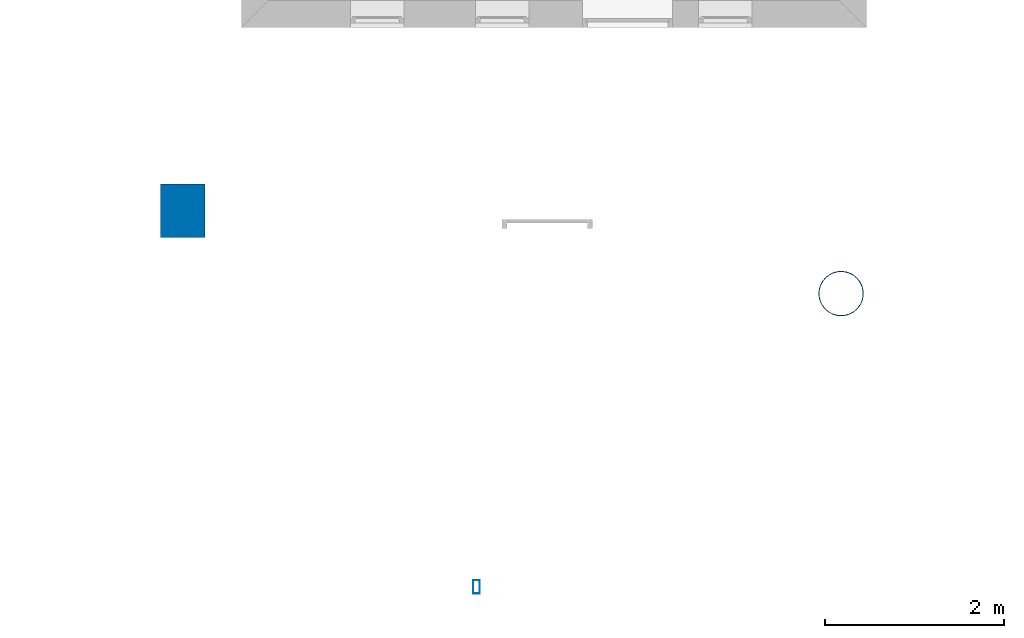
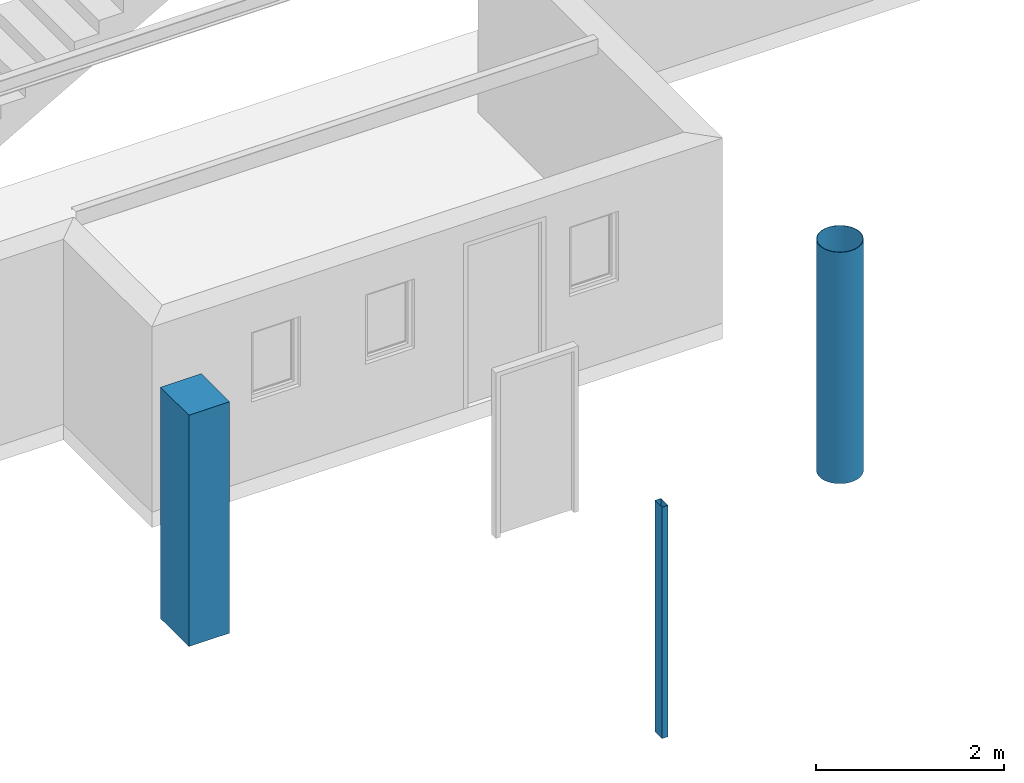
# One storey, part 1 of 5: 3 columns.
"""IFC4 building model written with IfcOpenShell, lengths in millimetres."""

from ifc_helpers import new_model, entity, si_unit, converted_unit, frame, origin_with_axes, origin_2d_with_axis, place, context, subcontext, project, spatial, rectangle, hollow_rectangle, hollow_circle, extrude, material, material_profile, profile_set, profile_usage, type_object, element, save


model = new_model("IFC4")

# Units and contexts
model_context = context("Model", 3, precision=1e-05, world=origin_with_axes())
plan_context = context("Plan", 2, precision=1e-05, world=origin_2d_with_axis())
body_context = subcontext(model_context, "Body", "Model", "MODEL_VIEW")
ifc_project = project(units=[si_unit("VOLUMEUNIT", "CUBIC_METRE"), si_unit("LENGTHUNIT", "METRE", prefix="MILLI"), converted_unit("PLANEANGLEUNIT", "degree", entity("IfcReal", 0.0174532925199433), si_unit("PLANEANGLEUNIT", "RADIAN"), dimensions=[0, 0, 0, 0, 0, 0, 0]), si_unit("AREAUNIT", "SQUARE_METRE")], contexts=[model_context, plan_context])

# Site, building, storey
site_placement = place(None, origin_with_axes())
site = spatial("IfcSite", under=ifc_project, at=site_placement)
building_placement = place(site_placement, origin_with_axes())
building = spatial("IfcBuilding", under=site, at=building_placement, Name="Building")
storey_placement = place(building_placement, origin_with_axes())
storey = spatial("IfcBuildingStorey", under=building, at=storey_placement, Name="Storey")

# Columns
ifc_material = material()
ifc_material_profile_1 = material_profile(ifc_material, rectangle(XDim=500.0, YDim=600.0))
ifc_profile_set_1 = profile_set([ifc_material_profile_1])
ifc_profile_usage_1 = profile_usage(ifc_profile_set_1)
column_type_1 = type_object("IfcColumnType", Name="C1", PredefinedType="NOTDEFINED", material=ifc_profile_set_1)
column_1_placement = place(storey_placement, frame((1724.94029998779, -8051.72920227051, 0.0), z_axis=(0.0, 0.0, 1.0), x_axis=(1.0, 0.0, 0.0)))
element("IfcColumn", 1, at=column_1_placement, inside=storey, type_object=column_type_1, material=ifc_profile_usage_1, Name="Column", context=body_context, shape_type="SweptSolid", body=[
    extrude(rectangle(XDim=500.0, YDim=600.0), origin_with_axes(), (0.0, 0.0, 1.0), 3000.0),
])
ifc_material_profile_2 = material_profile(ifc_material, hollow_circle(Radius=250.0, WallThickness=5.0))
ifc_profile_set_2 = profile_set([ifc_material_profile_2])
ifc_profile_usage_2 = profile_usage(ifc_profile_set_2, cardinal=5)
column_type_2 = type_object("IfcColumnType", Name="C2", PredefinedType="NOTDEFINED", material=ifc_profile_set_2)
column_2_placement = place(storey_placement, frame((9096.01402282715, -8979.72869873047, 0.0), z_axis=(0.0, 0.0, 1.0), x_axis=(1.0, 0.0, 0.0)))
element("IfcColumn", 2, at=column_2_placement, inside=storey, type_object=column_type_2, material=ifc_profile_usage_2, Name="Column", context=body_context, shape_type="SweptSolid", body=[
    extrude(hollow_circle(Radius=250.0, WallThickness=5.0), origin_with_axes(), (0.0, 0.0, 1.0), 3000.0),
])
ifc_material_profile_3 = material_profile(ifc_material, hollow_rectangle(XDim=75.0, YDim=150.0, WallThickness=2.0, InnerFilletRadius=5.0, OuterFilletRadius=5.0))
ifc_profile_set_3 = profile_set([ifc_material_profile_3])
ifc_profile_usage_3 = profile_usage(ifc_profile_set_3)
column_type_3 = type_object("IfcColumnType", Name="C3", PredefinedType="NOTDEFINED", material=ifc_profile_set_3)
column_3_placement = place(storey_placement, frame((5012.29572296143, -12265.3388977051, 0.0), z_axis=(0.0, 0.0, 1.0), x_axis=(1.0, 0.0, 0.0)))
element("IfcColumn", 3, at=column_3_placement, inside=storey, type_object=column_type_3, material=ifc_profile_usage_3, Name="Column", context=body_context, shape_type="SweptSolid", body=[
    extrude(hollow_rectangle(XDim=75.0, YDim=150.0, WallThickness=2.0, InnerFilletRadius=5.0, OuterFilletRadius=5.0), origin_with_axes(), (0.0, 0.0, 1.0), 3000.0),
])

save(model, "model.ifc")
